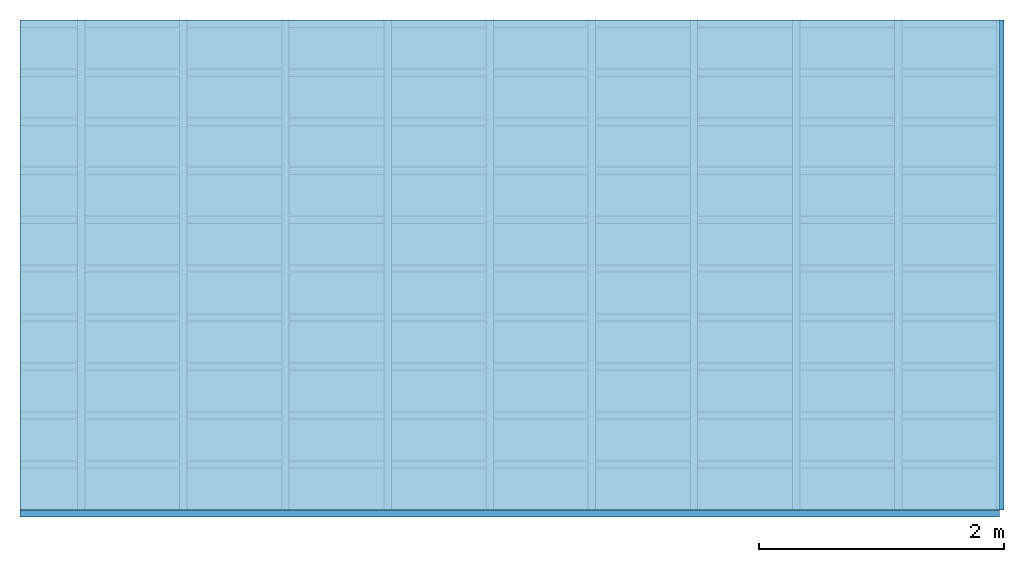
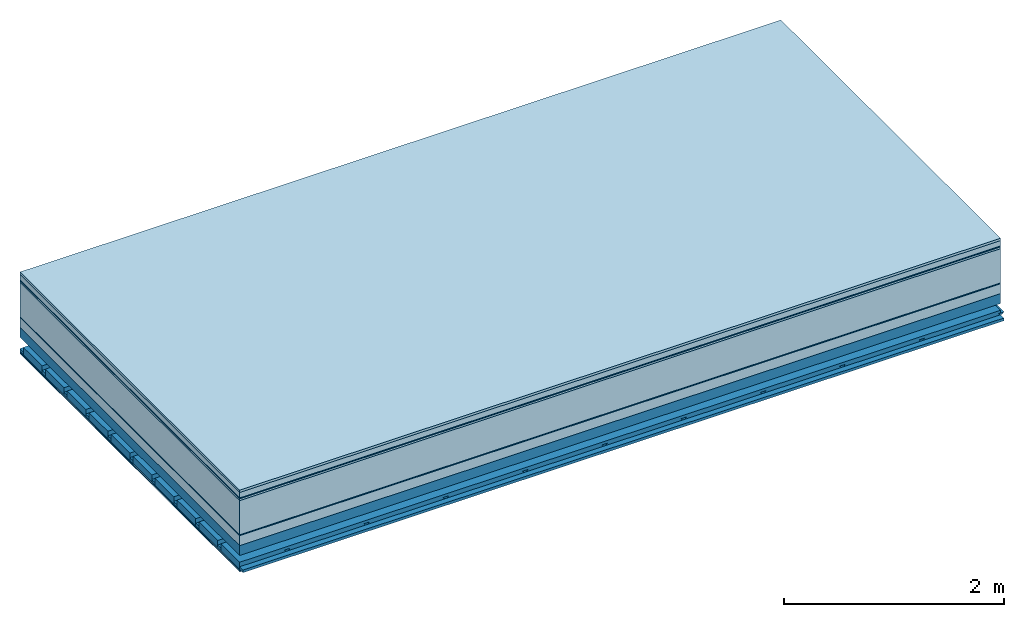
# One storey: 10 plates, 4 members, 1 element without a shape of its own.
"""IFC4 building model written with IfcOpenShell, lengths in metres."""

from ifc_helpers import new_model, si_unit, derived_unit, direction, frame, frame_2d, origin, origin_with_axes, place, context, project, spatial, polyline, rectangle, outline, extrude, material, layer, layer_set, type_object, element, aggregate, save


model = new_model("IFC4")

# Units and contexts
plan_context = context("Plan", 3, precision=1e-05, world=origin(), true_north=direction((0.0, 1.0)))
model_context = context("Model", 3, precision=1e-05, world=origin(), true_north=direction((0.0, 1.0)))
ifc_project = project(units=[si_unit("LENGTHUNIT", "METRE"), derived_unit("SOUNDPRESSUREUNIT", [(si_unit("PRESSUREUNIT", "PASCAL", prefix="MICRO"), 0)]), si_unit("ENERGYUNIT", "JOULE", prefix="MEGA"), si_unit("MASSUNIT", "GRAM", prefix="KILO"), derived_unit("THERMALTRANSMITTANCEUNIT", [(si_unit("POWERUNIT", "WATT"), 1), (si_unit("AREAUNIT", "SQUARE_METRE"), -1), (si_unit("THERMODYNAMICTEMPERATUREUNIT", "KELVIN"), -1)]), derived_unit("AREADENSITYUNIT", [(si_unit("MASSUNIT", "GRAM", prefix="KILO"), 1), (si_unit("AREAUNIT", "SQUARE_METRE"), -1)]), derived_unit("USERDEFINED", [(si_unit("ENERGYUNIT", "JOULE", prefix="MEGA"), 1), (si_unit("AREAUNIT", "SQUARE_METRE"), -1)])], contexts=[plan_context, model_context])

# Site, building, storey
site = spatial("IfcSite", under=ifc_project)
building_placement = place(None, origin())
building = spatial("IfcBuilding", under=site, at=building_placement)
storey_placement = place(building_placement, origin())
storey = spatial("IfcBuildingStorey", under=building, at=storey_placement)

# Slab, members, plates
ifc_material_1 = material(Category="07.009")
ifc_layer_1 = layer(ifc_material_1, 0.026, Name="Use and protection layer 3")
ifc_material_2 = material(Category="07.011")
ifc_layer_2 = layer(ifc_material_2, 0.06, Name="Use and protection layer 2")
ifc_material_3 = material(Name="Protective layer + Fire protection cover RF1", Category="09.007")
ifc_layer_3 = layer(ifc_material_3, 0.01, Name="Use and protection layer 1")
ifc_material_4 = material(Name="Bituminous", Category="09.003")
ifc_layer_4 = layer(ifc_material_4, 0.02, Name="Seal")
ifc_material_5 = material(Name="Mineral wool", Category="10.008")
ifc_layer_5 = layer(ifc_material_5, 0.38, Name="Exterior insulation layer 1")
ifc_material_6 = material(Name="Vapor-permeable barrier", Category="09.006")
ifc_layer_6 = layer(ifc_material_6, 0.01, Name="layer / temporary roof")
ifc_material_7 = material(Category="01.002")
ifc_layer_7 = layer(ifc_material_7, 0.11, Name="above 1st layer")
ifc_material_8 = material(Name="Rigid, of the art")
ifc_layer_8 = layer(ifc_material_8, 0.0, Name="Bond")
ifc_layer_9 = layer(None, 0.11, Name="Support")
ifc_material_9 = material(Name="no composite action")
ifc_layer_10 = layer(ifc_material_9, 0.0, Name="Bond")
ifc_layer_11 = layer(None, 0.125, Name="Coupling")
ifc_layer_12 = layer(None, 0.03, Name="Battens / profiles")
ifc_material_10 = material(Name="Plasterboard type A", Category="03.008")
ifc_layer_13 = layer(ifc_material_10, 0.0125, Name="Covering below 1st layer")
ifc_layer_14 = layer(ifc_material_10, 0.0125, Name="Covering below 2nd layer")
ifc_material_11 = material(Category="04.001")
ifc_layer_15 = layer(ifc_material_11, 0.003, Name="Surface below")
ifc_layer_set = layer_set([ifc_layer_1, ifc_layer_2, ifc_layer_3, ifc_layer_4, ifc_layer_5, ifc_layer_6, ifc_layer_7, ifc_layer_8, ifc_layer_9, ifc_layer_10, ifc_layer_11, ifc_layer_12, ifc_layer_13, ifc_layer_14, ifc_layer_15])
slab_type = type_object("IfcSlabType", Name="F0092", PredefinedType="NOTDEFINED", material=ifc_layer_set)
slab_placement = place(None, frame((0.0, 0.0, 0.0), z_axis=(0.0, 0.0, -1.0), x_axis=(1.0, 0.0, 0.0)))
slab = element("IfcSlab", 1, at=slab_placement, inside=storey, type_object=slab_type, material=ifc_layer_set, Name="Slab #1")
ifc_material_12 = material(Name="Solid timber panel")
member_1_placement = place(slab_placement, origin())
member_1 = element("IfcMember", 2, at=member_1_placement, material=ifc_material_12, Name="Support", context=plan_context, shape_type="SweptSolid", body=[
    extrude(rectangle(XDim=1.0, YDim=0.11, at=frame_2d((0.5, 0.055), x_axis=(1.0, 0.0))), frame((0.0, 4.0, 0.616), z_axis=(0.0, -1.0, 0.0), x_axis=(1.0, 0.0, 0.0)), (0.0, 0.0, 1.0), 4.0),
    extrude(rectangle(XDim=1.0, YDim=0.11, at=frame_2d((0.5, 0.055), x_axis=(1.0, 0.0))), frame((1.0, 4.0, 0.616), z_axis=(0.0, -1.0, 0.0), x_axis=(1.0, 0.0, 0.0)), (0.0, 0.0, 1.0), 4.0),
    extrude(rectangle(XDim=1.0, YDim=0.11, at=frame_2d((0.5, 0.055), x_axis=(1.0, 0.0))), frame((2.0, 4.0, 0.616), z_axis=(0.0, -1.0, 0.0), x_axis=(1.0, 0.0, 0.0)), (0.0, 0.0, 1.0), 4.0),
    extrude(rectangle(XDim=1.0, YDim=0.11, at=frame_2d((0.5, 0.055), x_axis=(1.0, 0.0))), frame((3.0, 4.0, 0.616), z_axis=(0.0, -1.0, 0.0), x_axis=(1.0, 0.0, 0.0)), (0.0, 0.0, 1.0), 4.0),
    extrude(rectangle(XDim=1.0, YDim=0.11, at=frame_2d((0.5, 0.055), x_axis=(1.0, 0.0))), frame((4.0, 4.0, 0.616), z_axis=(0.0, -1.0, 0.0), x_axis=(1.0, 0.0, 0.0)), (0.0, 0.0, 1.0), 4.0),
    extrude(rectangle(XDim=1.0, YDim=0.11, at=frame_2d((0.5, 0.055), x_axis=(1.0, 0.0))), frame((5.0, 4.0, 0.616), z_axis=(0.0, -1.0, 0.0), x_axis=(1.0, 0.0, 0.0)), (0.0, 0.0, 1.0), 4.0),
    extrude(rectangle(XDim=1.0, YDim=0.11, at=frame_2d((0.5, 0.055), x_axis=(1.0, 0.0))), frame((6.0, 4.0, 0.616), z_axis=(0.0, -1.0, 0.0), x_axis=(1.0, 0.0, 0.0)), (0.0, 0.0, 1.0), 4.0),
    extrude(rectangle(XDim=1.0, YDim=0.11, at=frame_2d((0.5, 0.055), x_axis=(1.0, 0.0))), frame((7.0, 4.0, 0.616), z_axis=(0.0, -1.0, 0.0), x_axis=(1.0, 0.0, 0.0)), (0.0, 0.0, 1.0), 4.0),
])
ifc_material_13 = material()
member_2_placement = place(slab_placement, origin())
member_2 = element("IfcMember", 3, at=member_2_placement, material=ifc_material_13, Name="Coupling", context=plan_context, shape_type="SweptSolid", body=[
    extrude(outline(polyline([(0.0, 0.0), (0.06, 0.0), (0.04, 0.02), (0.02, 0.02), (0.0, 0.0)])), frame((0.47, 4.0, 0.831), z_axis=(0.0, -1.0, 0.0), x_axis=(1.0, 0.0, 0.0)), (0.0, 0.0, 1.0), 4.0),
    extrude(outline(polyline([(0.0, 0.0), (0.06, 0.0), (0.04, 0.02), (0.02, 0.02), (0.0, 0.0)])), frame((1.304, 4.0, 0.831), z_axis=(0.0, -1.0, 0.0), x_axis=(1.0, 0.0, 0.0)), (0.0, 0.0, 1.0), 4.0),
    extrude(outline(polyline([(0.0, 0.0), (0.06, 0.0), (0.04, 0.02), (0.02, 0.02), (0.0, 0.0)])), frame((2.138, 4.0, 0.831), z_axis=(0.0, -1.0, 0.0), x_axis=(1.0, 0.0, 0.0)), (0.0, 0.0, 1.0), 4.0),
    extrude(outline(polyline([(0.0, 0.0), (0.06, 0.0), (0.04, 0.02), (0.02, 0.02), (0.0, 0.0)])), frame((2.972, 4.0, 0.831), z_axis=(0.0, -1.0, 0.0), x_axis=(1.0, 0.0, 0.0)), (0.0, 0.0, 1.0), 4.0),
    extrude(outline(polyline([(0.0, 0.0), (0.06, 0.0), (0.04, 0.02), (0.02, 0.02), (0.0, 0.0)])), frame((3.806, 4.0, 0.831), z_axis=(0.0, -1.0, 0.0), x_axis=(1.0, 0.0, 0.0)), (0.0, 0.0, 1.0), 4.0),
    extrude(outline(polyline([(0.0, 0.0), (0.06, 0.0), (0.04, 0.02), (0.02, 0.02), (0.0, 0.0)])), frame((4.64, 4.0, 0.831), z_axis=(0.0, -1.0, 0.0), x_axis=(1.0, 0.0, 0.0)), (0.0, 0.0, 1.0), 4.0),
    extrude(outline(polyline([(0.0, 0.0), (0.06, 0.0), (0.04, 0.02), (0.02, 0.02), (0.0, 0.0)])), frame((5.474, 4.0, 0.831), z_axis=(0.0, -1.0, 0.0), x_axis=(1.0, 0.0, 0.0)), (0.0, 0.0, 1.0), 4.0),
    extrude(outline(polyline([(0.0, 0.0), (0.06, 0.0), (0.04, 0.02), (0.02, 0.02), (0.0, 0.0)])), frame((6.308, 4.0, 0.831), z_axis=(0.0, -1.0, 0.0), x_axis=(1.0, 0.0, 0.0)), (0.0, 0.0, 1.0), 4.0),
    extrude(outline(polyline([(0.0, 0.0), (0.06, 0.0), (0.04, 0.02), (0.02, 0.02), (0.0, 0.0)])), frame((7.142, 4.0, 0.831), z_axis=(0.0, -1.0, 0.0), x_axis=(1.0, 0.0, 0.0)), (0.0, 0.0, 1.0), 4.0),
    extrude(outline(polyline([(0.0, 0.0), (0.06, 0.0), (0.04, 0.02), (0.02, 0.02), (0.0, 0.0)])), frame((7.976, 4.0, 0.831), z_axis=(0.0, -1.0, 0.0), x_axis=(1.0, 0.0, 0.0)), (0.0, 0.0, 1.0), 4.0),
])
member_3_placement = place(slab_placement, origin())
member_3 = element("IfcMember", 4, at=member_3_placement, material=ifc_material_13, Name="Battens / profiles", context=plan_context, shape_type="SweptSolid", body=[
    extrude(rectangle(XDim=0.06, YDim=0.03, at=frame_2d((0.03, 0.015), x_axis=(1.0, 0.0))), frame((0.0, 0.0, 0.851), z_axis=(1.0, 0.0, 0.0), x_axis=(0.0, 1.0, 0.0)), (0.0, 0.0, 1.0), 8.0),
    extrude(rectangle(XDim=0.06, YDim=0.03, at=frame_2d((0.03, 0.015), x_axis=(1.0, 0.0))), frame((0.0, 0.4, 0.851), z_axis=(1.0, 0.0, 0.0), x_axis=(0.0, 1.0, 0.0)), (0.0, 0.0, 1.0), 8.0),
    extrude(rectangle(XDim=0.06, YDim=0.03, at=frame_2d((0.03, 0.015), x_axis=(1.0, 0.0))), frame((0.0, 0.8, 0.851), z_axis=(1.0, 0.0, 0.0), x_axis=(0.0, 1.0, 0.0)), (0.0, 0.0, 1.0), 8.0),
    extrude(rectangle(XDim=0.06, YDim=0.03, at=frame_2d((0.03, 0.015), x_axis=(1.0, 0.0))), frame((0.0, 1.2, 0.851), z_axis=(1.0, 0.0, 0.0), x_axis=(0.0, 1.0, 0.0)), (0.0, 0.0, 1.0), 8.0),
    extrude(rectangle(XDim=0.06, YDim=0.03, at=frame_2d((0.03, 0.015), x_axis=(1.0, 0.0))), frame((0.0, 1.6, 0.851), z_axis=(1.0, 0.0, 0.0), x_axis=(0.0, 1.0, 0.0)), (0.0, 0.0, 1.0), 8.0),
    extrude(rectangle(XDim=0.06, YDim=0.03, at=frame_2d((0.03, 0.015), x_axis=(1.0, 0.0))), frame((0.0, 2.0, 0.851), z_axis=(1.0, 0.0, 0.0), x_axis=(0.0, 1.0, 0.0)), (0.0, 0.0, 1.0), 8.0),
    extrude(rectangle(XDim=0.06, YDim=0.03, at=frame_2d((0.03, 0.015), x_axis=(1.0, 0.0))), frame((0.0, 2.4, 0.851), z_axis=(1.0, 0.0, 0.0), x_axis=(0.0, 1.0, 0.0)), (0.0, 0.0, 1.0), 8.0),
    extrude(rectangle(XDim=0.06, YDim=0.03, at=frame_2d((0.03, 0.015), x_axis=(1.0, 0.0))), frame((0.0, 2.8, 0.851), z_axis=(1.0, 0.0, 0.0), x_axis=(0.0, 1.0, 0.0)), (0.0, 0.0, 1.0), 8.0),
    extrude(rectangle(XDim=0.06, YDim=0.03, at=frame_2d((0.03, 0.015), x_axis=(1.0, 0.0))), frame((0.0, 3.2, 0.851), z_axis=(1.0, 0.0, 0.0), x_axis=(0.0, 1.0, 0.0)), (0.0, 0.0, 1.0), 8.0),
    extrude(rectangle(XDim=0.06, YDim=0.03, at=frame_2d((0.03, 0.015), x_axis=(1.0, 0.0))), frame((0.0, 3.6, 0.851), z_axis=(1.0, 0.0, 0.0), x_axis=(0.0, 1.0, 0.0)), (0.0, 0.0, 1.0), 8.0),
    extrude(rectangle(XDim=0.06, YDim=0.03, at=frame_2d((0.03, 0.015), x_axis=(1.0, 0.0))), frame((0.0, 4.0, 0.851), z_axis=(1.0, 0.0, 0.0), x_axis=(0.0, 1.0, 0.0)), (0.0, 0.0, 1.0), 8.0),
])
ifc_material_14 = material()
member_4_placement = place(slab_placement, origin())
member_4 = element("IfcMember", 5, at=member_4_placement, material=ifc_material_14, Name="Cavity", context=plan_context, shape_type="SweptSolid", body=[
    extrude(rectangle(XDim=0.34, YDim=0.08, at=frame_2d((0.17, 0.04), x_axis=(1.0, 0.0))), frame((0.0, 0.06, 0.801), z_axis=(1.0, 0.0, 0.0), x_axis=(0.0, 1.0, 0.0)), (0.0, 0.0, 1.0), 8.0),
    extrude(rectangle(XDim=0.34, YDim=0.08, at=frame_2d((0.17, 0.04), x_axis=(1.0, 0.0))), frame((0.0, 0.46, 0.801), z_axis=(1.0, 0.0, 0.0), x_axis=(0.0, 1.0, 0.0)), (0.0, 0.0, 1.0), 8.0),
    extrude(rectangle(XDim=0.34, YDim=0.08, at=frame_2d((0.17, 0.04), x_axis=(1.0, 0.0))), frame((0.0, 0.86, 0.801), z_axis=(1.0, 0.0, 0.0), x_axis=(0.0, 1.0, 0.0)), (0.0, 0.0, 1.0), 8.0),
    extrude(rectangle(XDim=0.34, YDim=0.08, at=frame_2d((0.17, 0.04), x_axis=(1.0, 0.0))), frame((0.0, 1.26, 0.801), z_axis=(1.0, 0.0, 0.0), x_axis=(0.0, 1.0, 0.0)), (0.0, 0.0, 1.0), 8.0),
    extrude(rectangle(XDim=0.34, YDim=0.08, at=frame_2d((0.17, 0.04), x_axis=(1.0, 0.0))), frame((0.0, 1.66, 0.801), z_axis=(1.0, 0.0, 0.0), x_axis=(0.0, 1.0, 0.0)), (0.0, 0.0, 1.0), 8.0),
    extrude(rectangle(XDim=0.34, YDim=0.08, at=frame_2d((0.17, 0.04), x_axis=(1.0, 0.0))), frame((0.0, 2.06, 0.801), z_axis=(1.0, 0.0, 0.0), x_axis=(0.0, 1.0, 0.0)), (0.0, 0.0, 1.0), 8.0),
    extrude(rectangle(XDim=0.34, YDim=0.08, at=frame_2d((0.17, 0.04), x_axis=(1.0, 0.0))), frame((0.0, 2.46, 0.801), z_axis=(1.0, 0.0, 0.0), x_axis=(0.0, 1.0, 0.0)), (0.0, 0.0, 1.0), 8.0),
    extrude(rectangle(XDim=0.34, YDim=0.08, at=frame_2d((0.17, 0.04), x_axis=(1.0, 0.0))), frame((0.0, 2.86, 0.801), z_axis=(1.0, 0.0, 0.0), x_axis=(0.0, 1.0, 0.0)), (0.0, 0.0, 1.0), 8.0),
    extrude(rectangle(XDim=0.34, YDim=0.08, at=frame_2d((0.17, 0.04), x_axis=(1.0, 0.0))), frame((0.0, 3.26, 0.801), z_axis=(1.0, 0.0, 0.0), x_axis=(0.0, 1.0, 0.0)), (0.0, 0.0, 1.0), 8.0),
    extrude(rectangle(XDim=0.34, YDim=0.08, at=frame_2d((0.17, 0.04), x_axis=(1.0, 0.0))), frame((0.0, 3.66, 0.801), z_axis=(1.0, 0.0, 0.0), x_axis=(0.0, 1.0, 0.0)), (0.0, 0.0, 1.0), 8.0),
])
plate_1_placement = place(slab_placement, origin())
plate_1 = element("IfcPlate", 6, at=plate_1_placement, material=ifc_material_1, Name="Use and protection layer 3", context=plan_context, shape_type="SweptSolid", body=[
    extrude(rectangle(XDim=8.0, YDim=4.0, at=frame_2d((4.0, 2.0), x_axis=(1.0, 0.0))), origin_with_axes(), (0.0, 0.0, 1.0), 0.026),
])
plate_2_placement = place(slab_placement, origin())
plate_2 = element("IfcPlate", 7, at=plate_2_placement, material=ifc_material_2, Name="Use and protection layer 2", context=plan_context, shape_type="SweptSolid", body=[
    extrude(rectangle(XDim=8.0, YDim=4.0, at=frame_2d((4.0, 2.0), x_axis=(1.0, 0.0))), frame((0.0, 0.0, 0.026), z_axis=(0.0, 0.0, 1.0), x_axis=(1.0, 0.0, 0.0)), (0.0, 0.0, 1.0), 0.06),
])
plate_3_placement = place(slab_placement, origin())
plate_3 = element("IfcPlate", 8, at=plate_3_placement, material=ifc_material_3, Name="Use and protection layer 1", context=plan_context, shape_type="SweptSolid", body=[
    extrude(rectangle(XDim=8.0, YDim=4.0, at=frame_2d((4.0, 2.0), x_axis=(1.0, 0.0))), frame((0.0, 0.0, 0.086), z_axis=(0.0, 0.0, 1.0), x_axis=(1.0, 0.0, 0.0)), (0.0, 0.0, 1.0), 0.01),
])
plate_4_placement = place(slab_placement, origin())
plate_4 = element("IfcPlate", 9, at=plate_4_placement, material=ifc_material_4, Name="Seal", context=plan_context, shape_type="SweptSolid", body=[
    extrude(rectangle(XDim=8.0, YDim=4.0, at=frame_2d((4.0, 2.0), x_axis=(1.0, 0.0))), frame((0.0, 0.0, 0.096), z_axis=(0.0, 0.0, 1.0), x_axis=(1.0, 0.0, 0.0)), (0.0, 0.0, 1.0), 0.02),
])
plate_5_placement = place(slab_placement, origin())
plate_5 = element("IfcPlate", 10, at=plate_5_placement, material=ifc_material_5, Name="Exterior insulation layer 1", context=plan_context, shape_type="SweptSolid", body=[
    extrude(rectangle(XDim=8.0, YDim=4.0, at=frame_2d((4.0, 2.0), x_axis=(1.0, 0.0))), frame((0.0, 0.0, 0.116), z_axis=(0.0, 0.0, 1.0), x_axis=(1.0, 0.0, 0.0)), (0.0, 0.0, 1.0), 0.38),
])
plate_6_placement = place(slab_placement, origin())
plate_6 = element("IfcPlate", 11, at=plate_6_placement, material=ifc_material_6, Name="layer / temporary roof", context=plan_context, shape_type="SweptSolid", body=[
    extrude(rectangle(XDim=8.0, YDim=4.0, at=frame_2d((4.0, 2.0), x_axis=(1.0, 0.0))), frame((0.0, 0.0, 0.496), z_axis=(0.0, 0.0, 1.0), x_axis=(1.0, 0.0, 0.0)), (0.0, 0.0, 1.0), 0.01),
])
plate_7_placement = place(slab_placement, origin())
plate_7 = element("IfcPlate", 12, at=plate_7_placement, material=ifc_material_7, Name="above 1st layer", context=plan_context, shape_type="SweptSolid", body=[
    extrude(rectangle(XDim=8.0, YDim=4.0, at=frame_2d((4.0, 2.0), x_axis=(1.0, 0.0))), frame((0.0, 0.0, 0.506), z_axis=(0.0, 0.0, 1.0), x_axis=(1.0, 0.0, 0.0)), (0.0, 0.0, 1.0), 0.11),
])
plate_8_placement = place(slab_placement, origin())
plate_8 = element("IfcPlate", 13, at=plate_8_placement, material=ifc_material_10, Name="Covering below 1st layer", context=plan_context, shape_type="SweptSolid", body=[
    extrude(rectangle(XDim=8.0, YDim=4.0, at=frame_2d((4.0, 2.0), x_axis=(1.0, 0.0))), frame((0.0, 0.0, 0.881), z_axis=(0.0, 0.0, 1.0), x_axis=(1.0, 0.0, 0.0)), (0.0, 0.0, 1.0), 0.0125),
])
plate_9_placement = place(slab_placement, origin())
plate_9 = element("IfcPlate", 14, at=plate_9_placement, material=ifc_material_10, Name="Covering below 2nd layer", context=plan_context, shape_type="SweptSolid", body=[
    extrude(rectangle(XDim=8.0, YDim=4.0, at=frame_2d((4.0, 2.0), x_axis=(1.0, 0.0))), frame((0.0, 0.0, 0.8935), z_axis=(0.0, 0.0, 1.0), x_axis=(1.0, 0.0, 0.0)), (0.0, 0.0, 1.0), 0.0125),
])
plate_10_placement = place(slab_placement, origin())
plate_10 = element("IfcPlate", 15, at=plate_10_placement, material=ifc_material_11, Name="Surface below", context=plan_context, shape_type="SweptSolid", body=[
    extrude(rectangle(XDim=8.0, YDim=4.0, at=frame_2d((4.0, 2.0), x_axis=(1.0, 0.0))), frame((0.0, 0.0, 0.906), z_axis=(0.0, 0.0, 1.0), x_axis=(1.0, 0.0, 0.0)), (0.0, 0.0, 1.0), 0.003),
])
aggregate(slab, [plate_1, plate_2, plate_3, plate_4, plate_5, plate_6, plate_7, member_1, member_2, member_3, member_4, plate_8, plate_9, plate_10])

save(model, "model.ifc")
